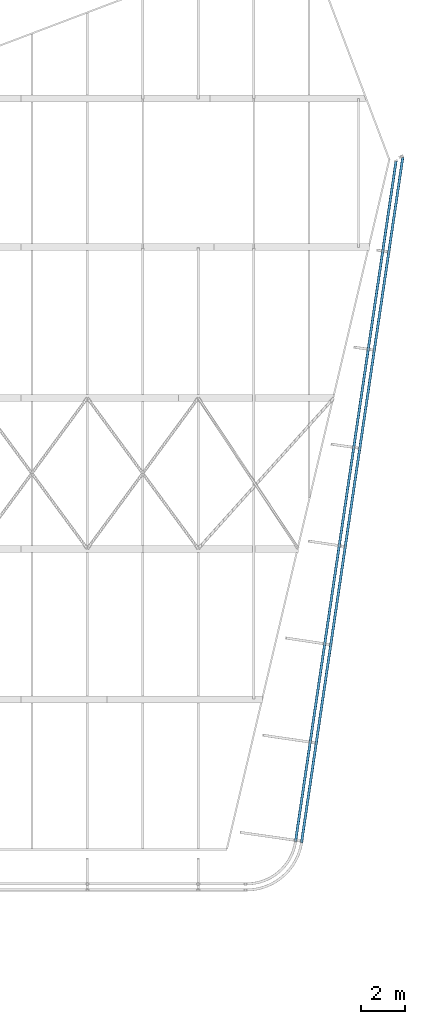
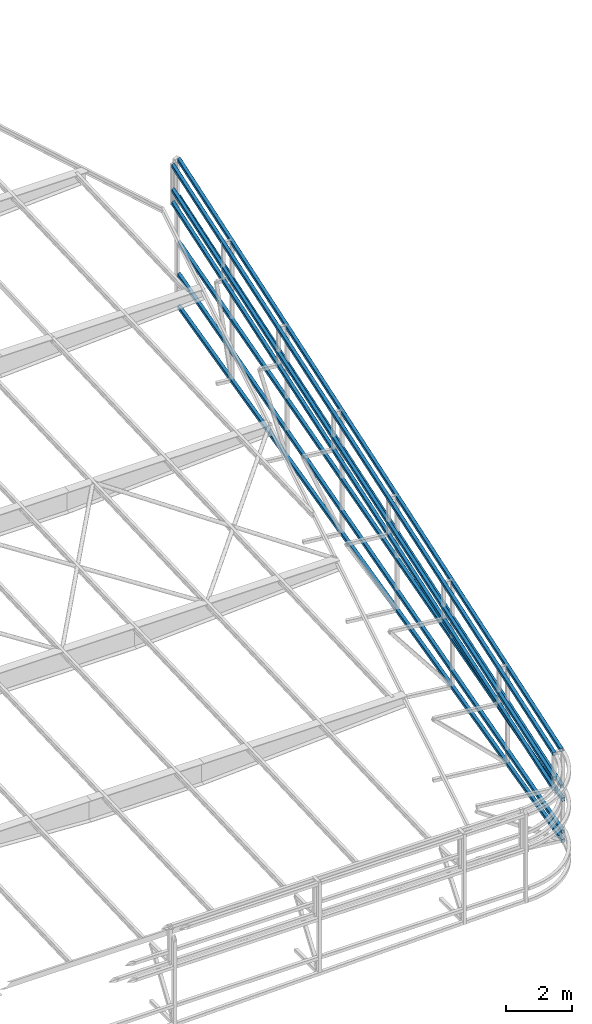
# One storey, part 121 of 215: 8 beams, 8 elements without a shape of their own.
"""IFC2X3 building model written with IfcOpenShell, lengths in millimetres."""

from ifc_helpers import new_model, si_unit, frame, origin_with_axes, origin_2d_with_axis, place, context, subcontext, project, spatial, hollow_rectangle, extrude, clip, halfspace, material, type_object, element, aggregate, save


model = new_model("IFC2X3")

# Units and contexts
model_context = context("Model", 3, precision=1e-05, world=origin_with_axes())
body_context = subcontext(model_context, "Body", "Model", "MODEL_VIEW")
ifc_project = project(units=[si_unit("LENGTHUNIT", "METRE", prefix="MILLI"), si_unit("AREAUNIT", "SQUARE_METRE"), si_unit("VOLUMEUNIT", "CUBIC_METRE"), si_unit("MASSUNIT", "GRAM", prefix="KILO"), si_unit("TIMEUNIT", "SECOND"), si_unit("PLANEANGLEUNIT", "RADIAN"), si_unit("SOLIDANGLEUNIT", "STERADIAN"), si_unit("THERMODYNAMICTEMPERATUREUNIT", "DEGREE_CELSIUS"), si_unit("LUMINOUSINTENSITYUNIT", "LUMEN")], contexts=[model_context])

# Site, building, storey
site_placement = place(None, origin_with_axes())
site = spatial("IfcSite", under=ifc_project, at=site_placement, CompositionType="ELEMENT")
building_placement = place(site_placement, origin_with_axes())
building = spatial("IfcBuilding", under=site, at=building_placement, Name="Undefined", CompositionType="ELEMENT")
storey_placement = place(building_placement, origin_with_axes())
storey = spatial("IfcBuildingStorey", under=building, at=storey_placement, Name="Undefined", CompositionType="ELEMENT", Elevation=0.0)

# Assembly, beam
assembly_1_placement = place(storey_placement, origin_with_axes())
assembly_1 = element("IfcElementAssembly", 1, at=assembly_1_placement, inside=storey, Name="Steel Assembly", AssemblyPlace="NOTDEFINED", PredefinedType="RIGID_FRAME")
ifc_material = material(Name="STEEL/S275JR")
beam_type = type_object("IfcBeamType", PredefinedType="NOTDEFINED")
beam_1_placement = place(assembly_1_placement, frame((149496.932772629, 35306.206617485, 1436.38444685494), z_axis=(1.9650000001293e-05, 0.000132988999993105, -0.999999990963902), x_axis=(0.146168875046812, 0.989259643316818, 0.000134433000043053)))
beam_1 = element("IfcBeam", 2, at=beam_1_placement, type_object=beam_type, material=ifc_material, Name="LISSE", context=body_context, shape_type="Clipping", body=[
    clip(clip(extrude(hollow_rectangle(XDim=120.0, YDim=120.0, WallThickness=4.0, InnerFilletRadius=4.0, OuterFilletRadius=8.0, at=origin_2d_with_axis()), frame((31768.2393821826, -1.95549210868204e-13, 8.61079853855048e-16), z_axis=(-1.0, 0.0, 0.0), x_axis=(-6.93889390390723e-18, -1.0, -3.46944695195361e-18)), (0.0, 0.0, 1.0), 31768.2), halfspace(frame((31923.2196731576, -59.9999995401013, -60.0000000000084), z_axis=(0.487277247501139, 0.873247318791564, 6.55061664794494e-05), x_axis=(-0.000134432870312596, -9.94768925011175e-11, 0.999999990963902)), False)), halfspace(frame((31669.2029088863, -102.997225370724, 2625.1718564591), z_axis=(0.873222017596538, -0.487322577154281, 0.000117389694816361), x_axis=(-0.000134432870312596, -9.94768925011175e-11, 0.999999990963902)), False)),
])
aggregate(assembly_1, [beam_1])

assembly_2_placement = place(storey_placement, origin_with_axes())
assembly_2 = element("IfcElementAssembly", 3, at=assembly_2_placement, inside=storey, Name="Steel Assembly", AssemblyPlace="NOTDEFINED", PredefinedType="RIGID_FRAME")
beam_2_placement = place(assembly_2_placement, frame((149221.660985636, 35356.8909091749, 3467.71598170075), z_axis=(0.00613477299813424, 0.0415196669873871, -0.999118852696474), x_axis=(0.146040093960899, 0.98838796673537, 0.0419704439887628)))
beam_2 = element("IfcBeam", 4, at=beam_2_placement, type_object=beam_type, material=ifc_material, Name="LISSE", context=body_context, shape_type="Clipping", body=[
    clip(extrude(hollow_rectangle(XDim=120.0, YDim=120.0, WallThickness=4.0, InnerFilletRadius=4.0, OuterFilletRadius=8.0, at=origin_2d_with_axis()), frame((31580.6037061077, 1.38062353205245e-12, 2.27373675443232e-13), z_axis=(-1.0, 0.0, 0.0), x_axis=(-6.93889390390723e-18, -1.0, -3.46944695195361e-18)), (0.0, 0.0, 1.0), 31580.6), halfspace(frame((31287.2145953658, -59.8300117614563, 4785.07062146806), z_axis=(0.872531529532159, -0.487180972369352, 0.0366528325443577), x_axis=(-0.0419704442012623, 2.58063664657552e-10, 0.999118852696489)), False)),
])
aggregate(assembly_2, [beam_2])

assembly_3_placement = place(storey_placement, origin_with_axes())
assembly_3 = element("IfcElementAssembly", 5, at=assembly_3_placement, inside=storey, Name="Steel Assembly", AssemblyPlace="NOTDEFINED", PredefinedType="RIGID_FRAME")
beam_3_placement = place(assembly_3_placement, frame((149230.046836223, 35413.668460184, 3057.24866716169), z_axis=(0.0058235629991879, 0.0394134239944166, -0.999206018858489), x_axis=(0.146052820963075, 0.988474198750089, 0.0398413339899271)))
beam_3 = element("IfcBeam", 6, at=beam_3_placement, type_object=beam_type, material=ifc_material, Name="LISSE", context=body_context, shape_type="Clipping", body=[
    clip(extrude(hollow_rectangle(XDim=120.0, YDim=120.0, WallThickness=4.0, InnerFilletRadius=4.0, OuterFilletRadius=8.0, at=origin_2d_with_axis()), frame((31520.0245259282, -2.84565512526806e-11, 0.0), z_axis=(-1.0, 0.0, 0.0), x_axis=(-6.93889390390723e-18, -1.0, -3.46944695195361e-18)), (0.0, 0.0, 1.0), 31520.0), halfspace(frame((31263.2607561597, -59.8262408715382, 4132.53444237944), z_axis=(0.872607658711062, -0.48718096003785, 0.0347934783457628), x_axis=(-0.0398413337753219, -1.12922862173094e-11, 0.999206018858475)), False)),
])
aggregate(assembly_3, [beam_3])

assembly_4_placement = place(storey_placement, origin_with_axes())
assembly_4 = element("IfcElementAssembly", 7, at=assembly_4_placement, inside=storey, Name="Steel Assembly", AssemblyPlace="NOTDEFINED", PredefinedType="RIGID_FRAME")
beam_4_placement = place(assembly_4_placement, frame((149221.660985512, 35356.8909093582, 4375.55598161047), z_axis=(0.00613477299813424, 0.0415196669873871, -0.999118852696474), x_axis=(0.146040093960899, 0.98838796673537, 0.0419704439887628)))
beam_4 = element("IfcBeam", 8, at=beam_4_placement, type_object=beam_type, material=ifc_material, Name="LISSE", context=body_context, shape_type="Clipping", body=[
    clip(extrude(hollow_rectangle(XDim=120.0, YDim=120.0, WallThickness=4.0, InnerFilletRadius=4.0, OuterFilletRadius=8.0, at=origin_2d_with_axis()), frame((31580.6037061077, 1.38062353205245e-12, 2.27373675443232e-13), z_axis=(-1.0, 0.0, 0.0), x_axis=(-6.93889390390723e-18, -1.0, -3.46944695195361e-18)), (0.0, 0.0, 1.0), 31580.6), halfspace(frame((31249.1121432383, -59.8299683704972, 5692.1107121515), z_axis=(0.872531529532159, -0.487180972369352, 0.0366528325443577), x_axis=(-0.0419704442012623, 2.58063664657552e-10, 0.999118852696489)), False)),
])
aggregate(assembly_4, [beam_4])

assembly_5_placement = place(storey_placement, origin_with_axes())
assembly_5 = element("IfcElementAssembly", 9, at=assembly_5_placement, inside=storey, Name="Steel Assembly", AssemblyPlace="NOTDEFINED", PredefinedType="RIGID_FRAME")
beam_5_placement = place(assembly_5_placement, frame((149496.932772742, 35306.2066174542, 2620.91444685494), z_axis=(1.9650000001293e-05, 0.000132988999993105, -0.999999990963902), x_axis=(0.146168875046812, 0.989259643316818, 0.000134433000043053)))
beam_5 = element("IfcBeam", 10, at=beam_5_placement, type_object=beam_type, material=ifc_material, Name="LISSE", context=body_context, shape_type="Clipping", body=[
    clip(clip(extrude(hollow_rectangle(XDim=120.0, YDim=120.0, WallThickness=4.0, InnerFilletRadius=4.0, OuterFilletRadius=8.0, at=origin_2d_with_axis()), frame((31768.2393821826, -1.95549210868204e-13, 8.61079853855048e-16), z_axis=(-1.0, 0.0, 0.0), x_axis=(-6.93889390390723e-18, -1.0, -3.46944695195361e-18)), (0.0, 0.0, 1.0), 31768.2), halfspace(frame((31923.2196731576, -59.9999995401013, -60.0000000000084), z_axis=(0.487277247501139, 0.873247318791564, 6.55061664794494e-05), x_axis=(-0.000134432870312596, -9.94768925011175e-11, 0.999999990963902)), False)), halfspace(frame((31669.2029088863, -102.997225370724, 2625.1718564591), z_axis=(0.873222017596538, -0.487322577154281, 0.000117389694816361), x_axis=(-0.000134432870312596, -9.94768925011175e-11, 0.999999990963902)), False)),
])
aggregate(assembly_5, [beam_5])

assembly_6_placement = place(storey_placement, origin_with_axes())
assembly_6 = element("IfcElementAssembly", 11, at=assembly_6_placement, inside=storey, Name="Steel Assembly", AssemblyPlace="NOTDEFINED", PredefinedType="RIGID_FRAME")
beam_6_placement = place(assembly_6_placement, frame((149507.809000494, 35379.8171693084, 3057.2486568051), z_axis=(0.0058235629991879, 0.0394134239944166, -0.999206018858489), x_axis=(0.146052820963075, 0.988474198750089, 0.0398413339899271)))
beam_6 = element("IfcBeam", 12, at=beam_6_placement, type_object=beam_type, material=ifc_material, Name="LISSE", context=body_context, shape_type="Clipping", body=[
    clip(clip(extrude(hollow_rectangle(XDim=120.0, YDim=120.0, WallThickness=4.0, InnerFilletRadius=4.0, OuterFilletRadius=8.0, at=origin_2d_with_axis()), frame((31726.1988020151, 6.84403817748596e-13, -5.7566313658986e-13), z_axis=(-1.0, 0.0, 0.0), x_axis=(-6.93889390390723e-18, -1.0, -3.46944695195361e-18)), (0.0, 0.0, 1.0), 31726.2), halfspace(frame((31876.5017127712, -59.999999541149, -60.0000000024273), z_axis=(0.486890362995696, 0.873247318768914, 0.0194137756457086), x_axis=(-0.0398413337753219, -1.12922862173094e-11, 0.999206018858475)), False)), halfspace(frame((31455.170079862, -102.997064796131, 4140.18643101814), z_axis=(0.872528703700349, -0.487322577093885, 0.0347903301732366), x_axis=(-0.0398413337753219, -1.12922862173094e-11, 0.999206018858475)), False)),
])
aggregate(assembly_6, [beam_6])

assembly_7_placement = place(storey_placement, origin_with_axes())
assembly_7 = element("IfcElementAssembly", 13, at=assembly_7_placement, inside=storey, Name="Steel Assembly", AssemblyPlace="NOTDEFINED", PredefinedType="RIGID_FRAME")
beam_7_placement = place(assembly_7_placement, frame((149497.165243419, 35307.7785256767, 1089.98144354476), z_axis=(-0.00384280100140723, -0.0260077810095812, -0.999654354368259), x_axis=(0.146118352035064, 0.988917719237311, -0.0262901460063088)))
beam_7 = element("IfcBeam", 14, at=beam_7_placement, type_object=beam_type, material=ifc_material, Name="LISSE", context=body_context, shape_type="Clipping", body=[
    clip(clip(extrude(hollow_rectangle(XDim=120.0, YDim=120.0, WallThickness=4.0, InnerFilletRadius=4.0, OuterFilletRadius=8.0, at=origin_2d_with_axis()), frame((31782.3746843333, -3.04294468511761e-11, -1.10267262974408e-13), z_axis=(-1.0, 0.0, 0.0), x_axis=(-6.93889390390723e-18, -1.0, -3.46944695195361e-18)), (0.0, 0.0, 1.0), 31782.4), halfspace(frame((31909.0104895769, -59.9999870265019, -899.224096312485), z_axis=(0.487108825745253, 0.873247319298242, -0.0128105901314239), x_axis=(0.0262901463017618, -9.94186848394296e-11, 0.999654354368265)), False)), halfspace(frame((31685.6764043058, -102.997380953544, 257.049232438083), z_axis=(0.872920200947622, -0.487322575647708, -0.0229571348745118), x_axis=(0.0262901463017618, -9.94186848394296e-11, 0.999654354368265)), False)),
])
aggregate(assembly_7, [beam_7])

assembly_8_placement = place(storey_placement, origin_with_axes())
assembly_8 = element("IfcElementAssembly", 15, at=assembly_8_placement, inside=storey, Name="Steel Assembly", AssemblyPlace="NOTDEFINED", PredefinedType="RIGID_FRAME")
beam_8_placement = place(assembly_8_placement, frame((149522.160842114, 35476.9533260148, 4375.5558628936), z_axis=(0.00613477299813424, 0.0415196669873871, -0.999118852696474), x_axis=(0.146040093960899, 0.98838796673537, 0.0419704439887628)))
beam_8 = element("IfcBeam", 16, at=beam_8_placement, type_object=beam_type, material=ifc_material, Name="LISSE", context=body_context, shape_type="Clipping", body=[
    clip(clip(clip(extrude(hollow_rectangle(XDim=120.0, YDim=120.0, WallThickness=4.0, InnerFilletRadius=4.0, OuterFilletRadius=8.0, at=origin_2d_with_axis()), frame((31628.268044071, -2.99062079333372e-11, 8.9367774353076e-13), z_axis=(-1.0, 0.0, 0.0), x_axis=(-6.93889390390723e-18, -1.0, -3.46944695195361e-18)), (0.0, 0.0, 1.0), 31719.9), halfspace(frame((31781.1336057778, -60.0, -59.9999999999991), z_axis=(0.486847900584174, 0.873247312277228, 0.0204512419519856), x_axis=(-0.0419704442012623, 2.58063664657552e-10, 0.999118852696489)), False)), halfspace(frame((31285.5576584844, -102.996880703664, 5693.64157694563), z_axis=(0.872452581860942, -0.487322588488213, 0.0366495177775153), x_axis=(-0.0419704442012623, 2.58063664657552e-10, 0.999118852696489)), False)), halfspace(frame((-105.726092278252, 45.1003780807368, 1435.51800118666), z_axis=(0.999108152934084, -0.00462149066368392, 0.041970710795602), x_axis=(0.0419711585135934, -1.07873260276798e-07, -0.999118822689782)), True)),
])
aggregate(assembly_8, [beam_8])

save(model, "model.ifc")
